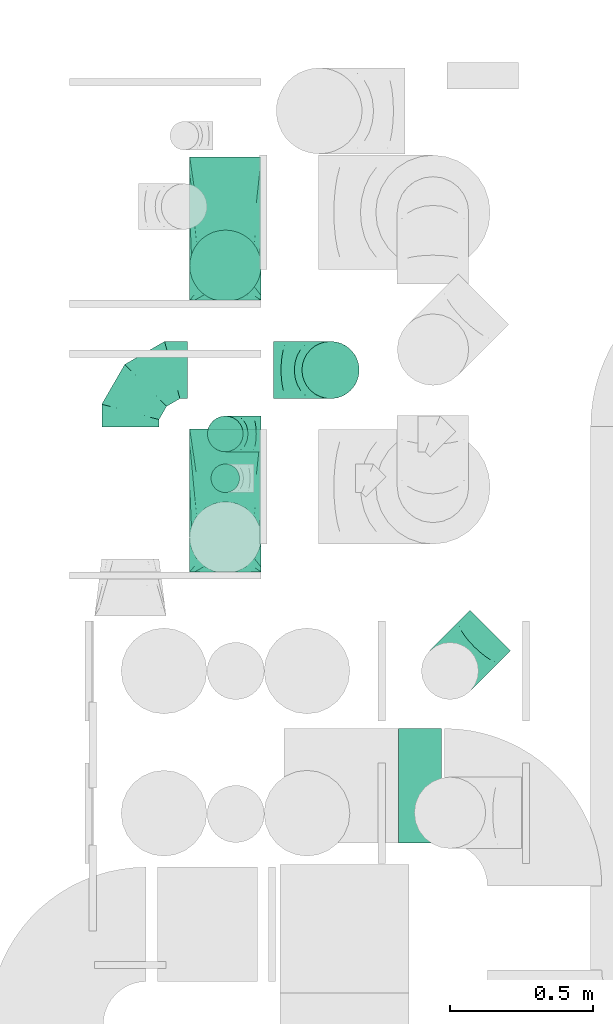
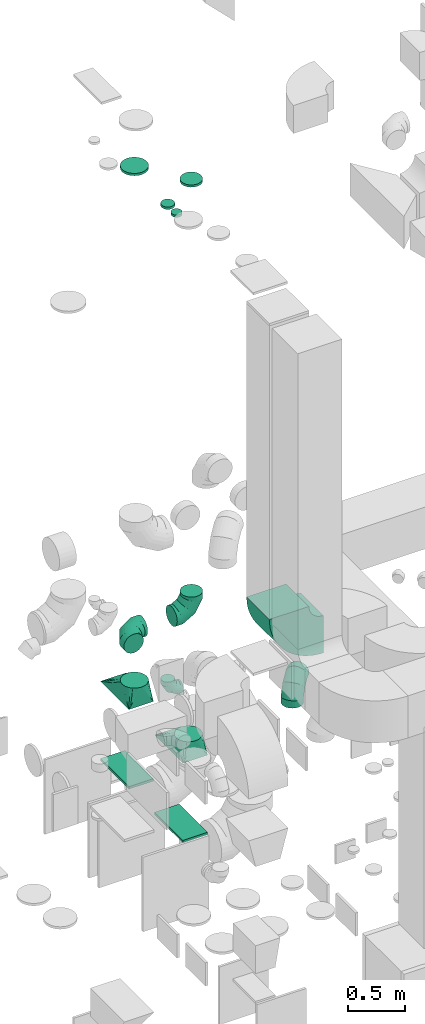
# One storey, part 25 of 59: 13 flow fittings.
"""IFC2X3 building model written with IfcOpenShell, lengths in millimetres."""

from ifc_helpers import new_model, entity, si_unit, converted_unit, derived_unit, direction, frame, frame_2d, origin, origin_2d_with_axis, place, context, subcontext, project, spatial, polyline, circle_curve, parameter, trimmed, segment, composite_curve, rectangle, circle, outline, extrude, faceted_brep, source, transform, mapped, material, type_object, type_shapes, element, save


model = new_model("IFC2X3")

# Units and contexts
model_context = context("Model", 3, precision=0.01, world=origin(), true_north=direction((6.12303176911189e-17, 1.0)))
body_context = subcontext(model_context, "Body", "Model", "MODEL_VIEW")
ifc_project = project(units=[si_unit("LENGTHUNIT", "METRE", prefix="MILLI"), si_unit("AREAUNIT", "SQUARE_METRE"), si_unit("VOLUMEUNIT", "CUBIC_METRE"), converted_unit("PLANEANGLEUNIT", "DEGREE", entity("IfcRatioMeasure", 0.0174532925199433), si_unit("PLANEANGLEUNIT", "RADIAN"), dimensions=[0, 0, 0, 0, 0, 0, 0]), si_unit("MASSUNIT", "GRAM", prefix="KILO"), derived_unit("MASSDENSITYUNIT", [(si_unit("MASSUNIT", "GRAM", prefix="KILO"), 1), (si_unit("LENGTHUNIT", "METRE"), -3)]), derived_unit("MOMENTOFINERTIAUNIT", [(si_unit("LENGTHUNIT", "METRE"), 4)]), si_unit("TIMEUNIT", "SECOND"), si_unit("FREQUENCYUNIT", "HERTZ"), si_unit("THERMODYNAMICTEMPERATUREUNIT", "DEGREE_CELSIUS"), derived_unit("THERMALTRANSMITTANCEUNIT", [(si_unit("MASSUNIT", "GRAM", prefix="KILO"), 1), (si_unit("THERMODYNAMICTEMPERATUREUNIT", "KELVIN"), -1), (si_unit("TIMEUNIT", "SECOND"), -3)]), derived_unit("VOLUMETRICFLOWRATEUNIT", [(si_unit("LENGTHUNIT", "METRE"), 3), (si_unit("TIMEUNIT", "SECOND"), -1)]), derived_unit("MASSFLOWRATEUNIT", [(si_unit("MASSUNIT", "GRAM", prefix="KILO"), 1), (si_unit("TIMEUNIT", "SECOND"), -1)]), derived_unit("ROTATIONALFREQUENCYUNIT", [(si_unit("TIMEUNIT", "SECOND"), -1)]), si_unit("ELECTRICCURRENTUNIT", "AMPERE"), si_unit("ELECTRICVOLTAGEUNIT", "VOLT"), si_unit("POWERUNIT", "WATT"), si_unit("FORCEUNIT", "NEWTON", prefix="KILO"), si_unit("ILLUMINANCEUNIT", "LUX"), si_unit("LUMINOUSFLUXUNIT", "LUMEN"), si_unit("LUMINOUSINTENSITYUNIT", "CANDELA"), derived_unit("USERDEFINED", [(si_unit("MASSUNIT", "GRAM", prefix="KILO"), -1), (si_unit("LENGTHUNIT", "METRE"), -2), (si_unit("TIMEUNIT", "SECOND"), 3), (si_unit("LUMINOUSFLUXUNIT", "LUMEN"), 1)]), derived_unit("LINEARVELOCITYUNIT", [(si_unit("LENGTHUNIT", "METRE"), 1), (si_unit("TIMEUNIT", "SECOND"), -1)]), si_unit("PRESSUREUNIT", "PASCAL"), derived_unit("USERDEFINED", [(si_unit("LENGTHUNIT", "METRE"), -2), (si_unit("MASSUNIT", "GRAM", prefix="KILO"), 1), (si_unit("TIMEUNIT", "SECOND"), -2)]), derived_unit("LINEARFORCEUNIT", [(si_unit("MASSUNIT", "GRAM", prefix="KILO"), 1), (si_unit("LENGTHUNIT", "METRE"), 1), (si_unit("TIMEUNIT", "SECOND"), -2), (si_unit("LENGTHUNIT", "METRE"), -1)]), derived_unit("PLANARFORCEUNIT", [(si_unit("MASSUNIT", "GRAM", prefix="KILO"), 1), (si_unit("LENGTHUNIT", "METRE"), 1), (si_unit("TIMEUNIT", "SECOND"), -2), (si_unit("LENGTHUNIT", "METRE"), -2)])], contexts=[model_context])

# Site, building, storey
site_placement = place(None, origin())
site = spatial("IfcSite", under=ifc_project, at=site_placement, CompositionType="ELEMENT")
building_placement = place(site_placement, origin())
building = spatial("IfcBuilding", under=site, at=building_placement, CompositionType="ELEMENT")
storey_placement = place(building_placement, frame((0.0, 0.0, 28200.0)))
storey = spatial("IfcBuildingStorey", under=building, at=storey_placement, CompositionType="ELEMENT", Elevation=28200.0)

# Flow fittings
ifc_material = material()
duct_fitting_type_1 = type_object("IfcDuctFittingType", PredefinedType="NOTDEFINED", material=ifc_material)
shared_shape_1 = source(origin(), body_context, "Body", "SweptSolid", [
    extrude(rectangle(XDim=250.0, YDim=26.0960000001597, at=origin_2d_with_axis()), frame((6.95, 0.0, -250.0), z_axis=(0.0, 0.0, 1.0), x_axis=(0.0, -1.0, 0.0)), (0.0, 0.0, 1.0), 500.0),
])
type_shapes(duct_fitting_type_1, [shared_shape_1])
for number, where, z_axis, x_axis in (
    (1, (55595.02, 11780.6, 1000.0), (0.0, 1.0, 0.0), (0.0, 0.0, 1.0)),
    (2, (55595.02, 10830.6, 1000.0), (0.0, 1.0, 0.0), (0.0, 0.0, 1.0)),
):
    element("IfcFlowFitting", number, at=place(storey_placement, frame(where, z_axis=z_axis, x_axis=x_axis)), inside=storey, type_object=duct_fitting_type_1, material=ifc_material, context=body_context, shape_type="MappedRepresentation", body=[
        mapped(shared_shape_1, transform((0.0, 0.0, 0.0), scale=1.0)),
    ])
duct_fitting_type_2 = type_object("IfcDuctFittingType", PredefinedType="NOTDEFINED", material=ifc_material)
shared_shape_2 = source(origin(), body_context, "Body", "SweptSolid", [
    extrude(circle(Radius=49.9999999999997, at=origin_2d_with_axis()), frame((0.0, 0.0, 0.0), z_axis=(1.0, 0.0, 0.0), x_axis=(0.0, 1.0, 0.0)), (0.0, 0.0, 1.0), 25.0000000000018),
])
type_shapes(duct_fitting_type_2, [shared_shape_2])
flow_fitting_1_placement = place(storey_placement, frame((55594.42, 10907.71, 7500.0), z_axis=(-1.0, 0.0, 0.0), x_axis=(0.0, 0.0, 1.0)))
element("IfcFlowFitting", 3, at=flow_fitting_1_placement, inside=storey, type_object=duct_fitting_type_2, material=ifc_material, context=body_context, shape_type="MappedRepresentation", body=[
    mapped(shared_shape_2, transform((0.0, 0.0, 0.0), scale=1.0)),
])
duct_fitting_type_3 = type_object("IfcDuctFittingType", PredefinedType="NOTDEFINED", material=ifc_material)
shared_shape_3 = source(origin(), body_context, "Body", "SweptSolid", [
    extrude(circle(Radius=62.4999999999996, at=origin_2d_with_axis()), frame((0.0, 0.0, 0.0), z_axis=(1.0, 0.0, 0.0), x_axis=(0.0, 1.0, 0.0)), (0.0, 0.0, 1.0), 25.0000000000018),
])
type_shapes(duct_fitting_type_3, [shared_shape_3])
flow_fitting_2_placement = place(storey_placement, frame((55594.42, 11063.0, 7500.0), z_axis=(-1.0, 0.0, 0.0), x_axis=(0.0, 0.0, 1.0)))
element("IfcFlowFitting", 4, at=flow_fitting_2_placement, inside=storey, type_object=duct_fitting_type_3, material=ifc_material, context=body_context, shape_type="MappedRepresentation", body=[
    mapped(shared_shape_3, transform((0.0, 0.0, 0.0), scale=1.0)),
])
duct_fitting_type_4 = type_object("IfcDuctFittingType", PredefinedType="NOTDEFINED", material=ifc_material)
shared_shape_4 = source(origin(), body_context, "Body", "SweptSolid", [
    extrude(circle(Radius=99.9999999999994, at=origin_2d_with_axis()), frame((0.0, 0.0, 0.0), z_axis=(1.0, 0.0, 0.0), x_axis=(0.0, 1.0, 0.0)), (0.0, 0.0, 1.0), 25.0000000000018),
])
type_shapes(duct_fitting_type_4, [shared_shape_4])
flow_fitting_3_placement = place(storey_placement, frame((55962.5, 11286.24, 7500.0), z_axis=(-1.0, 0.0, 0.0), x_axis=(0.0, 0.0, 1.0)))
element("IfcFlowFitting", 5, at=flow_fitting_3_placement, inside=storey, type_object=duct_fitting_type_4, material=ifc_material, context=body_context, shape_type="MappedRepresentation", body=[
    mapped(shared_shape_4, transform((0.0, 0.0, 0.0), scale=1.0)),
])
duct_fitting_type_5 = type_object("IfcDuctFittingType", PredefinedType="NOTDEFINED", material=ifc_material)
shared_shape_5 = source(origin(), body_context, "Body", "SweptSolid", [
    extrude(circle(Radius=124.999999999999, at=origin_2d_with_axis()), frame((0.0, 0.0, 0.0), z_axis=(1.0, 0.0, 0.0), x_axis=(0.0, 1.0, 0.0)), (0.0, 0.0, 1.0), 25.0000000000018),
])
type_shapes(duct_fitting_type_5, [shared_shape_5])
flow_fitting_4_placement = place(storey_placement, frame((55595.02, 11650.6, 7548.56), z_axis=(0.0, 1.0, 0.0), x_axis=(0.0, 0.0, 1.0)))
element("IfcFlowFitting", 6, at=flow_fitting_4_placement, inside=storey, type_object=duct_fitting_type_5, material=ifc_material, context=body_context, shape_type="MappedRepresentation", body=[
    mapped(shared_shape_5, transform((0.0, 0.0, 0.0), scale=1.0)),
])
duct_fitting_type_6 = type_object("IfcDuctFittingType", PredefinedType="NOTDEFINED", material=ifc_material)
shared_shape_6 = source(origin(), body_context, "Body", "Brep", [
    faceted_brep([(-200.0, 0.0, -100.0), (-200.0, -25.88, -96.59), (-200.0, -50.0, -86.6), (-200.0, -70.71, -70.71), (-200.0, -86.6, -50.0), (-200.0, -96.59, -25.88), (-200.0, -100.0, 0.0), (-200.0, -96.59, 25.88), (-200.0, -86.6, 50.0), (-200.0, -70.71, 70.71), (-200.0, -50.0, 86.6), (-200.0, -25.88, 96.59), (-200.0, 0.0, 100.0), (-200.0, 25.88, 96.59), (-200.0, 50.0, 86.6), (-200.0, 70.71, 70.71), (-200.0, 86.6, 50.0), (-200.0, 96.59, 25.88), (-200.0, 100.0, 0.0), (-200.0, 96.59, -25.88), (-200.0, 86.6, -50.0), (-200.0, 70.71, -70.71), (-200.0, 50.0, -86.6), (-200.0, 25.88, -96.59), (-153.35, 25.88, 96.59), (-159.81, 50.0, 86.6), (-146.41, 0.0, 100.0), (-165.36, 70.71, 70.71), (-172.29, 96.59, 25.88), (-173.21, 100.0, 0.0), (-169.62, 86.6, 50.0), (-169.62, 86.6, -50.0), (-165.36, 70.71, -70.71), (-172.29, 96.59, -25.88), (-153.35, 25.88, -96.59), (-146.41, 0.0, -100.0), (-159.81, 50.0, -86.6), (-139.48, -25.88, -96.59), (-133.01, -50.0, -86.6), (-127.46, -70.71, -70.71), (-123.21, -86.6, -50.0), (-120.53, -96.59, -25.88), (-119.62, -100.0, 0.0), (-120.53, -96.59, 25.88), (-123.21, -86.6, 50.0), (-127.46, -70.71, 70.71), (-133.01, -50.0, 86.6), (-139.48, -25.88, 96.59), (-72.54, 72.54, 96.59), (-90.19, 90.19, 86.6), (-53.59, 53.59, 100.0), (-105.35, 105.35, 70.71), (-116.99, 116.99, 50.0), (-124.3, 124.3, 25.88), (-126.79, 126.79, 0.0), (-124.3, 124.3, -25.88), (-116.99, 116.99, -50.0), (-105.35, 105.35, -70.71), (-72.54, 72.54, -96.59), (-53.59, 53.59, -100.0), (-90.19, 90.19, -86.6), (-34.64, 34.64, -96.59), (-16.99, 16.99, -86.6), (-1.83, 1.83, -70.71), (9.81, -9.81, -50.0), (17.12, -17.12, -25.88), (19.62, -19.62, 0.0), (17.12, -17.12, 25.88), (9.81, -9.81, 50.0), (-1.83, 1.83, 70.71), (-16.99, 16.99, 86.6), (-34.64, 34.64, 96.59), (-25.88, 153.35, 96.59), (-50.0, 159.81, 86.6), (0.0, 146.41, 100.0), (-70.71, 165.36, 70.71), (-86.6, 169.62, 50.0), (-96.59, 172.29, 25.88), (-100.0, 173.21, 0.0), (-96.59, 172.29, -25.88), (-86.6, 169.62, -50.0), (-70.71, 165.36, -70.71), (-25.88, 153.35, -96.59), (0.0, 146.41, -100.0), (-50.0, 159.81, -86.6), (25.88, 139.48, -96.59), (50.0, 133.01, -86.6), (70.71, 127.46, -70.71), (86.6, 123.21, -50.0), (96.59, 120.53, -25.88), (100.0, 119.62, 0.0), (96.59, 120.53, 25.88), (86.6, 123.21, 50.0), (70.71, 127.46, 70.71), (50.0, 133.01, 86.6), (25.88, 139.48, 96.59), (-25.88, 200.0, -96.59), (-50.0, 200.0, -86.6), (-70.71, 200.0, -70.71), (-86.6, 200.0, -50.0), (-96.59, 200.0, -25.88), (-100.0, 200.0, 0.0), (-96.59, 200.0, 25.88), (-86.6, 200.0, 50.0), (-70.71, 200.0, 70.71), (-50.0, 200.0, 86.6), (-25.88, 200.0, 96.59), (0.0, 200.0, 100.0), (25.88, 200.0, 96.59), (50.0, 200.0, 86.6), (70.71, 200.0, 70.71), (86.6, 200.0, 50.0), (96.59, 200.0, 25.88), (100.0, 200.0, 0.0), (96.59, 200.0, -25.88), (86.6, 200.0, -50.0), (70.71, 200.0, -70.71), (50.0, 200.0, -86.6), (25.88, 200.0, -96.59), (0.0, 200.0, -100.0)], [[[0, 1, 2, 3, 4, 5, 6, 7, 8, 9, 10, 11, 12, 13, 14, 15, 16, 17, 18, 19, 20, 21, 22, 23]], [[24, 25, 14, 13]], [[26, 24, 13, 12]], [[14, 25, 27, 15]], [[28, 29, 18, 17]], [[30, 28, 17, 16]], [[15, 27, 30, 16]], [[20, 31, 32, 21]], [[33, 31, 20, 19]], [[18, 29, 33, 19]], [[34, 35, 0, 23]], [[36, 34, 23, 22]], [[32, 36, 22, 21]], [[1, 0, 35, 37]], [[2, 1, 37, 38]], [[38, 39, 3, 2]], [[5, 4, 40, 41]], [[6, 5, 41, 42]], [[39, 40, 4, 3]], [[6, 42, 43, 7]], [[7, 43, 44, 8]], [[8, 44, 45, 9]], [[9, 45, 46, 10]], [[10, 46, 47, 11]], [[26, 12, 11, 47]], [[48, 49, 25, 24]], [[50, 48, 24, 26]], [[27, 25, 49, 51]], [[52, 53, 28, 30]], [[51, 52, 30, 27]], [[29, 28, 53, 54]], [[55, 56, 31, 33]], [[54, 55, 33, 29]], [[32, 31, 56, 57]], [[58, 59, 35, 34]], [[60, 58, 34, 36]], [[57, 60, 36, 32]], [[37, 35, 59, 61]], [[38, 37, 61, 62]], [[39, 38, 62, 63]], [[41, 40, 64, 65]], [[42, 41, 65, 66]], [[63, 64, 40, 39]], [[43, 42, 66, 67]], [[44, 43, 67, 68]], [[68, 69, 45, 44]], [[46, 45, 69, 70]], [[47, 46, 70, 71]], [[26, 47, 71, 50]], [[72, 73, 49, 48]], [[74, 72, 48, 50]], [[51, 49, 73, 75]], [[76, 77, 53, 52]], [[75, 76, 52, 51]], [[54, 53, 77, 78]], [[79, 80, 56, 55]], [[78, 79, 55, 54]], [[57, 56, 80, 81]], [[82, 83, 59, 58]], [[84, 82, 58, 60]], [[81, 84, 60, 57]], [[61, 59, 83, 85]], [[62, 61, 85, 86]], [[63, 62, 86, 87]], [[65, 64, 88, 89]], [[66, 65, 89, 90]], [[87, 88, 64, 63]], [[67, 66, 90, 91]], [[68, 67, 91, 92]], [[92, 93, 69, 68]], [[70, 69, 93, 94]], [[71, 70, 94, 95]], [[50, 71, 95, 74]], [[96, 97, 98, 99, 100, 101, 102, 103, 104, 105, 106, 107, 108, 109, 110, 111, 112, 113, 114, 115, 116, 117, 118, 119]], [[72, 74, 107, 106]], [[73, 72, 106, 105]], [[75, 73, 105, 104]], [[102, 101, 78, 77]], [[103, 102, 77, 76]], [[75, 104, 103, 76]], [[78, 101, 100, 79]], [[79, 100, 99, 80]], [[80, 99, 98, 81]], [[84, 97, 96, 82]], [[82, 96, 119, 83]], [[84, 81, 98, 97]], [[118, 117, 86, 85]], [[119, 118, 85, 83]], [[116, 87, 86, 117]], [[88, 115, 114, 89]], [[89, 114, 113, 90]], [[115, 88, 87, 116]], [[91, 90, 113, 112]], [[92, 91, 112, 111]], [[111, 110, 93, 92]], [[95, 94, 109, 108]], [[74, 95, 108, 107]], [[110, 109, 94, 93]]]),
])
type_shapes(duct_fitting_type_6, [shared_shape_6])
for number, where, z_axis, x_axis in (
    (7, (55262.5, 11286.24, 2900.0), (0.0, 0.0, 1.0), (-1.0, 0.0, 0.0)),
    (8, (55962.5, 11286.24, 2900.0), (0.0, -1.0, 0.0), (1.0, 0.0, 0.0)),
    (9, (56380.0, 10234.06, 2600.0), (-0.707106781186547, 0.707106781186549, 0.0), (0.0, 0.0, 1.0)),
):
    element("IfcFlowFitting", number, at=place(storey_placement, frame(where, z_axis=z_axis, x_axis=x_axis)), inside=storey, type_object=duct_fitting_type_6, material=ifc_material, context=body_context, shape_type="MappedRepresentation", body=[
        mapped(shared_shape_6, transform((0.0, 0.0, 0.0), scale=1.0)),
    ])
duct_fitting_type_7 = type_object("IfcDuctFittingType", PredefinedType="NOTDEFINED", material=ifc_material)
shared_shape_7 = source(origin(), body_context, "Body", "Brep", [
    faceted_brep([(-125.0, 0.0, -62.5), (-125.0, -16.18, -60.37), (-125.0, -31.25, -54.13), (-125.0, -44.19, -44.19), (-125.0, -54.13, -31.25), (-125.0, -60.37, -16.18), (-125.0, -62.5, 0.0), (-125.0, -60.37, 16.18), (-125.0, -54.13, 31.25), (-125.0, -44.19, 44.19), (-125.0, -31.25, 54.13), (-125.0, -16.18, 60.37), (-125.0, 0.0, 62.5), (-125.0, 16.18, 60.37), (-125.0, 31.25, 54.13), (-125.0, 44.19, 44.19), (-125.0, 54.13, 31.25), (-125.0, 60.37, 16.18), (-125.0, 62.5, 0.0), (-125.0, 60.37, -16.18), (-125.0, 54.13, -31.25), (-125.0, 44.19, -44.19), (-125.0, 31.25, -54.13), (-125.0, 16.18, -60.37), (-95.84, 16.18, 60.37), (-99.88, 31.25, 54.13), (-91.51, 0.0, 62.5), (-103.35, 44.19, 44.19), (-107.68, 60.37, 16.18), (-108.25, 62.5, 0.0), (-106.01, 54.13, 31.25), (-106.01, 54.13, -31.25), (-103.35, 44.19, -44.19), (-107.68, 60.37, -16.18), (-95.84, 16.18, -60.37), (-91.51, 0.0, -62.5), (-99.88, 31.25, -54.13), (-87.17, -16.18, -60.37), (-83.13, -31.25, -54.13), (-79.66, -44.19, -44.19), (-77.0, -54.13, -31.25), (-75.33, -60.37, -16.18), (-74.76, -62.5, 0.0), (-75.33, -60.37, 16.18), (-77.0, -54.13, 31.25), (-79.66, -44.19, 44.19), (-83.13, -31.25, 54.13), (-87.17, -16.18, 60.37), (-45.34, 45.34, 60.37), (-56.37, 56.37, 54.13), (-33.49, 33.49, 62.5), (-65.85, 65.85, 44.19), (-73.12, 73.12, 31.25), (-77.69, 77.69, 16.18), (-79.25, 79.25, 0.0), (-77.69, 77.69, -16.18), (-73.12, 73.12, -31.25), (-65.85, 65.85, -44.19), (-45.34, 45.34, -60.37), (-33.49, 33.49, -62.5), (-56.37, 56.37, -54.13), (-21.65, 21.65, -60.37), (-10.62, 10.62, -54.13), (-1.14, 1.14, -44.19), (6.13, -6.13, -31.25), (10.7, -10.7, -16.18), (12.26, -12.26, 0.0), (10.7, -10.7, 16.18), (6.13, -6.13, 31.25), (-1.14, 1.14, 44.19), (-10.62, 10.62, 54.13), (-21.65, 21.65, 60.37), (-16.18, 95.84, 60.37), (-31.25, 99.88, 54.13), (0.0, 91.51, 62.5), (-44.19, 103.35, 44.19), (-54.13, 106.01, 31.25), (-60.37, 107.68, 16.18), (-62.5, 108.25, 0.0), (-60.37, 107.68, -16.18), (-54.13, 106.01, -31.25), (-44.19, 103.35, -44.19), (-16.18, 95.84, -60.37), (0.0, 91.51, -62.5), (-31.25, 99.88, -54.13), (16.18, 87.17, -60.37), (31.25, 83.13, -54.13), (44.19, 79.66, -44.19), (54.13, 77.0, -31.25), (60.37, 75.33, -16.18), (62.5, 74.76, 0.0), (60.37, 75.33, 16.18), (54.13, 77.0, 31.25), (44.19, 79.66, 44.19), (31.25, 83.13, 54.13), (16.18, 87.17, 60.37), (-16.18, 125.0, -60.37), (-31.25, 125.0, -54.13), (-44.19, 125.0, -44.19), (-54.13, 125.0, -31.25), (-60.37, 125.0, -16.18), (-62.5, 125.0, 0.0), (-60.37, 125.0, 16.18), (-54.13, 125.0, 31.25), (-44.19, 125.0, 44.19), (-31.25, 125.0, 54.13), (-16.18, 125.0, 60.37), (0.0, 125.0, 62.5), (16.18, 125.0, 60.37), (31.25, 125.0, 54.13), (44.19, 125.0, 44.19), (54.13, 125.0, 31.25), (60.37, 125.0, 16.18), (62.5, 125.0, 0.0), (60.37, 125.0, -16.18), (54.13, 125.0, -31.25), (44.19, 125.0, -44.19), (31.25, 125.0, -54.13), (16.18, 125.0, -60.37), (0.0, 125.0, -62.5)], [[[0, 1, 2, 3, 4, 5, 6, 7, 8, 9, 10, 11, 12, 13, 14, 15, 16, 17, 18, 19, 20, 21, 22, 23]], [[24, 25, 14, 13]], [[26, 24, 13, 12]], [[14, 25, 27, 15]], [[28, 29, 18, 17]], [[30, 28, 17, 16]], [[15, 27, 30, 16]], [[20, 31, 32, 21]], [[33, 31, 20, 19]], [[18, 29, 33, 19]], [[34, 35, 0, 23]], [[36, 34, 23, 22]], [[21, 32, 36, 22]], [[1, 0, 35, 37]], [[2, 1, 37, 38]], [[38, 39, 3, 2]], [[5, 4, 40, 41]], [[6, 5, 41, 42]], [[39, 40, 4, 3]], [[6, 42, 43, 7]], [[7, 43, 44, 8]], [[45, 9, 8, 44]], [[9, 45, 46, 10]], [[10, 46, 47, 11]], [[26, 12, 11, 47]], [[48, 49, 25, 24]], [[50, 48, 24, 26]], [[27, 25, 49, 51]], [[52, 53, 28, 30]], [[51, 52, 30, 27]], [[29, 28, 53, 54]], [[55, 56, 31, 33]], [[54, 55, 33, 29]], [[57, 32, 31, 56]], [[58, 59, 35, 34]], [[60, 58, 34, 36]], [[57, 60, 36, 32]], [[37, 35, 59, 61]], [[38, 37, 61, 62]], [[39, 38, 62, 63]], [[41, 40, 64, 65]], [[42, 41, 65, 66]], [[63, 64, 40, 39]], [[43, 42, 66, 67]], [[44, 43, 67, 68]], [[68, 69, 45, 44]], [[46, 45, 69, 70]], [[47, 46, 70, 71]], [[26, 47, 71, 50]], [[72, 73, 49, 48]], [[74, 72, 48, 50]], [[51, 49, 73, 75]], [[76, 77, 53, 52]], [[75, 76, 52, 51]], [[54, 53, 77, 78]], [[79, 80, 56, 55]], [[78, 79, 55, 54]], [[81, 57, 56, 80]], [[82, 83, 59, 58]], [[84, 82, 58, 60]], [[81, 84, 60, 57]], [[61, 59, 83, 85]], [[62, 61, 85, 86]], [[63, 62, 86, 87]], [[65, 64, 88, 89]], [[66, 65, 89, 90]], [[87, 88, 64, 63]], [[67, 66, 90, 91]], [[68, 67, 91, 92]], [[92, 93, 69, 68]], [[70, 69, 93, 94]], [[71, 70, 94, 95]], [[50, 71, 95, 74]], [[96, 97, 98, 99, 100, 101, 102, 103, 104, 105, 106, 107, 108, 109, 110, 111, 112, 113, 114, 115, 116, 117, 118, 119]], [[72, 74, 107, 106]], [[73, 72, 106, 105]], [[75, 73, 105, 104]], [[77, 76, 103, 102]], [[78, 77, 102, 101]], [[75, 104, 103, 76]], [[78, 101, 100, 79]], [[79, 100, 99, 80]], [[80, 99, 98, 81]], [[96, 119, 83, 82]], [[97, 96, 82, 84]], [[84, 81, 98, 97]], [[83, 119, 118, 85]], [[85, 118, 117, 86]], [[116, 87, 86, 117]], [[88, 115, 114, 89]], [[89, 114, 113, 90]], [[115, 88, 87, 116]], [[91, 90, 113, 112]], [[92, 91, 112, 111]], [[111, 110, 93, 92]], [[95, 94, 109, 108]], [[74, 95, 108, 107]], [[110, 109, 94, 93]]]),
])
type_shapes(duct_fitting_type_7, [shared_shape_7])
flow_fitting_5_placement = place(storey_placement, frame((55594.42, 11063.0, 2300.0), z_axis=(0.0, -1.0, 0.0), x_axis=(0.0, 0.0, -1.0)))
element("IfcFlowFitting", 10, at=flow_fitting_5_placement, inside=storey, type_object=duct_fitting_type_7, material=ifc_material, context=body_context, shape_type="MappedRepresentation", body=[
    mapped(shared_shape_7, transform((0.0, 0.0, 0.0), scale=1.0)),
])
duct_fitting_type_8 = type_object("IfcDuctFittingType", PredefinedType="NOTDEFINED", material=ifc_material)
shared_shape_8 = source(origin(), body_context, "Body", "Brep", [
    faceted_brep([(200.0, -38.63, -248.88), (200.0, -23.84, -251.22), (200.0, -11.92, -253.11), (200.0, -5.96, -254.06), (200.0, 0.0, -255.0), (200.0, 5.96, -254.06), (200.0, 11.92, -253.11), (200.0, 23.84, -251.22), (200.0, 38.63, -248.88), (200.0, 56.05, -240.0), (200.0, 73.47, -231.13), (200.0, 87.3, -217.3), (200.0, 101.13, -203.47), (200.0, 110.0, -186.05), (200.0, 118.88, -168.63), (200.0, 121.22, -153.84), (200.0, 123.11, -141.92), (200.0, 124.06, -135.96), (200.0, 125.0, -130.0), (200.0, 124.06, -124.04), (200.0, 123.11, -118.08), (200.0, 121.22, -106.16), (200.0, 118.88, -91.37), (200.0, 110.0, -73.95), (200.0, 101.13, -56.53), (200.0, 87.3, -42.7), (200.0, 73.47, -28.87), (200.0, 56.05, -20.0), (200.0, 38.63, -11.12), (200.0, 23.84, -8.78), (200.0, 11.92, -6.89), (200.0, 5.96, -5.94), (200.0, 0.0, -5.0), (200.0, -5.96, -5.94), (200.0, -11.92, -6.89), (200.0, -23.84, -8.78), (200.0, -38.63, -11.12), (200.0, -56.05, -20.0), (200.0, -73.47, -28.87), (200.0, -87.3, -42.7), (200.0, -101.13, -56.53), (200.0, -110.0, -73.95), (200.0, -118.88, -91.37), (200.0, -121.22, -106.16), (200.0, -123.11, -118.08), (200.0, -124.06, -124.04), (200.0, -125.0, -130.0), (200.0, -124.06, -135.96), (200.0, -123.11, -141.92), (200.0, -121.22, -153.84), (200.0, -118.88, -168.63), (200.0, -110.0, -186.05), (200.0, -101.13, -203.47), (200.0, -87.3, -217.3), (200.0, -73.47, -231.13), (200.0, -56.05, -240.0), (0.0, -125.0, 250.0), (0.0, 125.0, 250.0), (0.0, 125.0, -250.0), (0.0, -125.0, -250.0), (104.11, -59.93, 117.25), (100.0, -103.94, 106.79), (26.03, -108.73, 216.81), (78.09, -76.2, 150.44), (52.06, -92.46, 183.63), (188.01, -7.49, 10.28), (176.03, -14.98, 25.56), (152.06, -29.96, 56.13), (128.09, -44.95, 86.69), (52.06, -125.0, 151.09), (78.09, -125.0, 101.64), (104.11, -125.0, 52.18), (128.09, -125.0, 6.64), (152.06, -125.0, -38.91), (176.03, -125.0, -84.45), (188.01, -125.0, -107.23), (26.03, -125.0, 200.55), (26.03, -125.0, -234.38), (52.06, -125.0, -218.77), (78.09, -125.0, -203.15), (104.11, -125.0, -187.53), (128.09, -125.0, -173.15), (152.06, -125.0, -158.77), (176.03, -125.0, -144.38), (188.01, -125.0, -137.19), (100.0, -109.29, -231.44), (52.06, -92.46, -251.3), (78.09, -76.2, -251.95), (104.11, -59.93, -252.6), (128.09, -44.95, -253.2), (152.06, -29.96, -253.8), (176.03, -14.98, -254.4), (188.01, -7.49, -254.7), (26.03, -108.73, -250.65), (26.03, 108.73, -250.65), (52.06, 92.46, -251.3), (78.09, 76.2, -251.95), (104.11, 59.93, -252.6), (128.09, 44.95, -253.2), (152.06, 29.96, -253.8), (176.03, 14.98, -254.4), (188.01, 7.49, -254.7), (100.0, 103.94, -236.79), (52.06, 125.0, -218.77), (78.09, 125.0, -203.15), (104.11, 125.0, -187.53), (128.09, 125.0, -173.15), (152.06, 125.0, -158.77), (176.03, 125.0, -144.38), (188.01, 125.0, -137.19), (26.03, 125.0, -234.38), (26.03, 125.0, 200.55), (52.06, 125.0, 151.09), (78.09, 125.0, 101.64), (104.11, 125.0, 52.18), (128.09, 125.0, 6.64), (152.06, 125.0, -38.91), (176.03, 125.0, -84.45), (188.01, 125.0, -107.23), (100.0, 109.29, 101.44), (52.06, 92.46, 183.63), (78.09, 76.2, 150.44), (104.11, 59.93, 117.25), (128.09, 44.95, 86.69), (152.06, 29.96, 56.13), (176.03, 14.98, 25.56), (188.01, 7.49, 10.28), (26.03, 108.73, 216.81)], [[[0, 1, 2, 3, 4, 5, 6, 7, 8, 9, 10, 11, 12, 13, 14, 15, 16, 17, 18, 19, 20, 21, 22, 23, 24, 25, 26, 27, 28, 29, 30, 31, 32, 33, 34, 35, 36, 37, 38, 39, 40, 41, 42, 43, 44, 45, 46, 47, 48, 49, 50, 51, 52, 53, 54, 55]], [[56, 57, 58, 59]], [[60, 37, 36]], [[56, 61, 62]], [[37, 60, 63, 64]], [[65, 66, 67, 68, 60, 36, 35, 34, 33, 32]], [[62, 61, 38]], [[41, 69, 70, 71]], [[64, 38, 37]], [[42, 71, 72, 73, 74, 75, 46, 45, 44, 43]], [[40, 76, 69]], [[71, 42, 41]], [[61, 76, 39]], [[38, 64, 62]], [[76, 40, 39]], [[38, 61, 39]], [[61, 56, 76]], [[69, 41, 40]], [[75, 74, 73, 72, 71, 70, 69, 76, 56, 59, 77, 78, 79, 80, 81, 82, 83, 84, 46]], [[80, 51, 50]], [[59, 85, 77]], [[51, 80, 79, 78]], [[84, 83, 82, 81, 80, 50, 49, 48, 47, 46]], [[77, 85, 52]], [[55, 86, 87, 88]], [[78, 52, 51]], [[0, 88, 89, 90, 91, 92, 4, 3, 2, 1]], [[54, 93, 86]], [[88, 0, 55]], [[85, 93, 53]], [[52, 78, 77]], [[93, 54, 53]], [[52, 85, 53]], [[85, 59, 93]], [[86, 55, 54]], [[92, 91, 90, 89, 88, 87, 86, 93, 59, 58, 94, 95, 96, 97, 98, 99, 100, 101, 4]], [[97, 9, 8]], [[58, 102, 94]], [[9, 97, 96, 95]], [[101, 100, 99, 98, 97, 8, 7, 6, 5, 4]], [[94, 102, 10]], [[13, 103, 104, 105]], [[95, 10, 9]], [[14, 105, 106, 107, 108, 109, 18, 17, 16, 15]], [[12, 110, 103]], [[105, 14, 13]], [[102, 110, 11]], [[10, 95, 94]], [[110, 12, 11]], [[10, 102, 11]], [[102, 58, 110]], [[103, 13, 12]], [[58, 57, 111, 112, 113, 114, 115, 116, 117, 118, 18, 109, 108, 107, 106, 105, 104, 103, 110]], [[114, 23, 22]], [[57, 119, 111]], [[23, 114, 113, 112]], [[118, 117, 116, 115, 114, 22, 21, 20, 19, 18]], [[111, 119, 24]], [[27, 120, 121, 122]], [[112, 24, 23]], [[28, 122, 123, 124, 125, 126, 32, 31, 30, 29]], [[26, 127, 120]], [[122, 28, 27]], [[119, 127, 25]], [[24, 112, 111]], [[127, 26, 25]], [[24, 119, 25]], [[119, 57, 127]], [[120, 27, 26]], [[57, 56, 62, 64, 63, 60, 68, 67, 66, 65, 32, 126, 125, 124, 123, 122, 121, 120, 127]]]),
])
type_shapes(duct_fitting_type_8, [shared_shape_8])
for number, where, z_axis, x_axis in (
    (11, (55595.02, 11780.6, 1848.56), (0.0, 1.0, 0.0), (0.0, 0.0, 1.0)),
    (12, (55595.02, 10830.6, 1848.56), (0.0, 1.0, 0.0), (0.0, 0.0, 1.0)),
):
    element("IfcFlowFitting", number, at=place(storey_placement, frame(where, z_axis=z_axis, x_axis=x_axis)), inside=storey, type_object=duct_fitting_type_8, material=ifc_material, context=body_context, shape_type="MappedRepresentation", body=[
        mapped(shared_shape_8, transform((0.0, 0.0, 0.0), scale=1.0)),
    ])
duct_fitting_type_9 = type_object("IfcDuctFittingType", PredefinedType="NOTDEFINED", material=ifc_material)
shared_shape_9 = source(origin(), body_context, "Body", "SweptSolid", [
    extrude(outline(composite_curve([segment(polyline([(-375.0, -175.0), (25.0, -175.0)]), True, "CONTINUOUS"), segment(trimmed(circle_curve(frame_2d((175.0, -175.0), x_axis=(0.0, 1.0)), 150.0), [parameter(0.0)], [parameter(90.0)], True, "PARAMETER"), False, "CONTINUOUS"), segment(polyline([(175.0, -25.0), (175.0, 375.0)]), True, "CONTINUOUS"), segment(trimmed(circle_curve(frame_2d((175.0, -175.0), x_axis=(0.0, 1.0)), 550.0), [parameter(0.0)], [parameter(90.0)], True, "PARAMETER"), True, "CONTINUOUS")], self_intersect=False)), frame((-175.0, 175.0, -200.0), z_axis=(0.0, 0.0, 1.0), x_axis=(-1.0, 0.0, 0.0)), (0.0, 0.0, 1.0), 400.0),
])
type_shapes(duct_fitting_type_9, [shared_shape_9])
flow_fitting_6_placement = place(storey_placement, frame((56000.5, 9833.0, 3500.0), z_axis=(0.0, 1.0, 0.0), x_axis=(-1.0, 0.0, 0.0)))
element("IfcFlowFitting", 13, at=flow_fitting_6_placement, inside=storey, type_object=duct_fitting_type_9, material=ifc_material, context=body_context, shape_type="MappedRepresentation", body=[
    mapped(shared_shape_9, transform((0.0, 0.0, 0.0), scale=1.0)),
])

save(model, "model.ifc")
